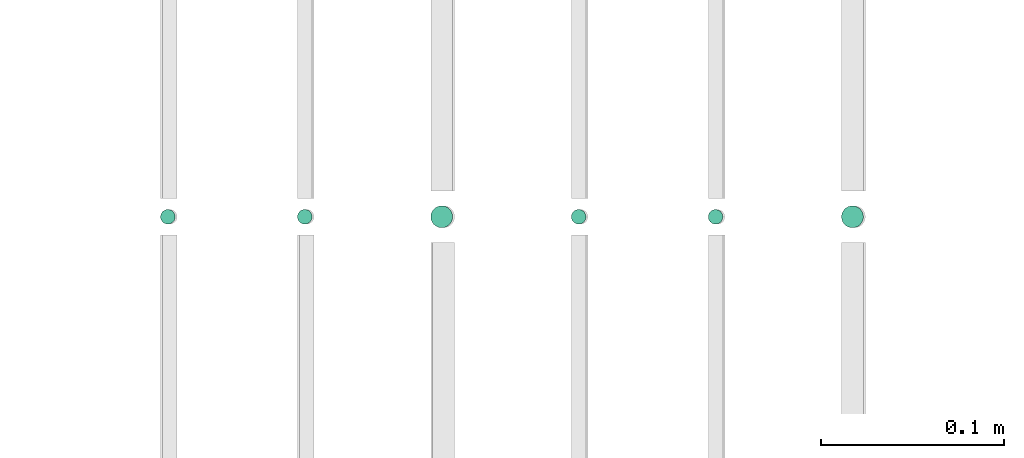
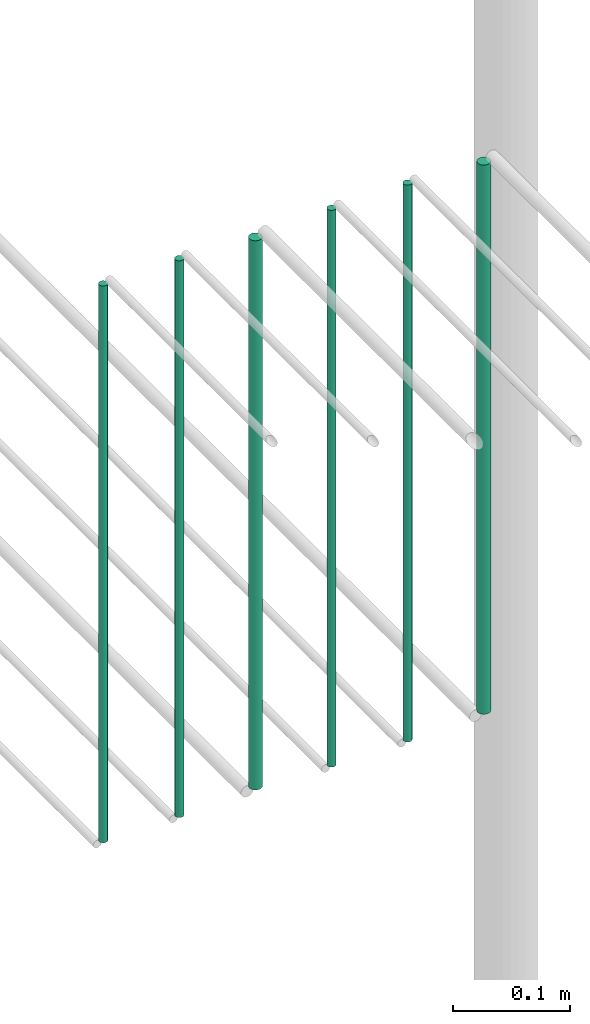
# One storey, part 213 of 331: 6 flow segments.
"""IFC2X3 building model written with IfcOpenShell, lengths in millimetres."""

from ifc_helpers import new_model, entity, si_unit, converted_unit, derived_unit, direction, frame, frame_2d, origin, origin_2d_with_axis, place, context, subcontext, project, spatial, circle, extrude, type_object, element, save


model = new_model("IFC2X3")

# Units and contexts
model_context = context("Model", 3, precision=0.01, world=origin(), true_north=direction((6.12303176911189e-17, 1.0)))
body_context = subcontext(model_context, "Body", "Model", "MODEL_VIEW")
ifc_project = project(units=[si_unit("LENGTHUNIT", "METRE", prefix="MILLI"), si_unit("AREAUNIT", "SQUARE_METRE"), si_unit("VOLUMEUNIT", "CUBIC_METRE"), converted_unit("PLANEANGLEUNIT", "DEGREE", entity("IfcRatioMeasure", 0.0174532925199433), si_unit("PLANEANGLEUNIT", "RADIAN"), dimensions=[0, 0, 0, 0, 0, 0, 0]), si_unit("MASSUNIT", "GRAM", prefix="KILO"), derived_unit("MASSDENSITYUNIT", [(si_unit("MASSUNIT", "GRAM", prefix="KILO"), 1), (si_unit("LENGTHUNIT", "METRE"), -3)]), derived_unit("MOMENTOFINERTIAUNIT", [(si_unit("LENGTHUNIT", "METRE"), 4)]), si_unit("TIMEUNIT", "SECOND"), si_unit("FREQUENCYUNIT", "HERTZ"), si_unit("THERMODYNAMICTEMPERATUREUNIT", "DEGREE_CELSIUS"), derived_unit("THERMALTRANSMITTANCEUNIT", [(si_unit("MASSUNIT", "GRAM", prefix="KILO"), 1), (si_unit("THERMODYNAMICTEMPERATUREUNIT", "KELVIN"), -1), (si_unit("TIMEUNIT", "SECOND"), -3)]), derived_unit("VOLUMETRICFLOWRATEUNIT", [(si_unit("LENGTHUNIT", "METRE"), 3), (si_unit("TIMEUNIT", "SECOND"), -1)]), derived_unit("MASSFLOWRATEUNIT", [(si_unit("MASSUNIT", "GRAM", prefix="KILO"), 1), (si_unit("TIMEUNIT", "SECOND"), -1)]), derived_unit("ROTATIONALFREQUENCYUNIT", [(si_unit("TIMEUNIT", "SECOND"), -1)]), si_unit("ELECTRICCURRENTUNIT", "AMPERE"), si_unit("ELECTRICVOLTAGEUNIT", "VOLT"), si_unit("POWERUNIT", "WATT"), si_unit("FORCEUNIT", "NEWTON", prefix="KILO"), si_unit("ILLUMINANCEUNIT", "LUX"), si_unit("LUMINOUSFLUXUNIT", "LUMEN"), si_unit("LUMINOUSINTENSITYUNIT", "CANDELA"), derived_unit("USERDEFINED", [(si_unit("MASSUNIT", "GRAM", prefix="KILO"), -1), (si_unit("LENGTHUNIT", "METRE"), -2), (si_unit("TIMEUNIT", "SECOND"), 3), (si_unit("LUMINOUSFLUXUNIT", "LUMEN"), 1)]), derived_unit("LINEARVELOCITYUNIT", [(si_unit("LENGTHUNIT", "METRE"), 1), (si_unit("TIMEUNIT", "SECOND"), -1)]), si_unit("PRESSUREUNIT", "PASCAL"), derived_unit("USERDEFINED", [(si_unit("LENGTHUNIT", "METRE"), -2), (si_unit("MASSUNIT", "GRAM", prefix="KILO"), 1), (si_unit("TIMEUNIT", "SECOND"), -2)]), derived_unit("LINEARFORCEUNIT", [(si_unit("MASSUNIT", "GRAM", prefix="KILO"), 1), (si_unit("LENGTHUNIT", "METRE"), 1), (si_unit("TIMEUNIT", "SECOND"), -2), (si_unit("LENGTHUNIT", "METRE"), -1)]), derived_unit("PLANARFORCEUNIT", [(si_unit("MASSUNIT", "GRAM", prefix="KILO"), 1), (si_unit("LENGTHUNIT", "METRE"), 1), (si_unit("TIMEUNIT", "SECOND"), -2), (si_unit("LENGTHUNIT", "METRE"), -2)])], contexts=[model_context])

# Site, building, storey
site_placement = place(None, frame((0.0, -0.00077364408347762, 0.0)))
site = spatial("IfcSite", under=ifc_project, at=site_placement, CompositionType="ELEMENT")
building_placement = place(site_placement, origin())
building = spatial("IfcBuilding", under=site, at=building_placement, CompositionType="ELEMENT")
storey_placement = place(building_placement, origin())
storey = spatial("IfcBuildingStorey", under=building, at=storey_placement, CompositionType="ELEMENT", Elevation=0.0)

# Flow segments
pipe_segment_type = type_object("IfcPipeSegmentType", PredefinedType="NOTDEFINED")
flow_segment_1_placement = place(storey_placement, frame((61864.4468045266, 5638.02529159137, 18460.0)))
element("IfcFlowSegment", 1, at=flow_segment_1_placement, inside=storey, type_object=pipe_segment_type, context=body_context, shape_type="SweptSolid", body=[
    extrude(circle(Radius=4.0, at=frame_2d((0.0, -1.08286712929839e-12), x_axis=(1.0, 0.0))), frame((5.59527223591499, 5.59527223591499, 0.0), z_axis=(0.0, 0.0, 1.0), x_axis=(-1.0, 0.0, 0.0)), (0.0, 0.0, 1.0), 580.000000000015),
])
flow_segment_2_placement = place(storey_placement, frame((61939.4468045266, 5638.02529159137, 18460.0)))
element("IfcFlowSegment", 2, at=flow_segment_2_placement, inside=storey, type_object=pipe_segment_type, context=body_context, shape_type="SweptSolid", body=[
    extrude(circle(Radius=4.0, at=frame_2d((0.0, -1.08286712929839e-12), x_axis=(1.0, 0.0))), frame((5.59527223591499, 5.59527223591499, 0.0), z_axis=(0.0, 0.0, 1.0), x_axis=(-1.0, 0.0, 0.0)), (0.0, 0.0, 1.0), 580.000000000007),
])
flow_segment_3_placement = place(storey_placement, frame((62012.4468045266, 5636.02529159137, 18464.0)))
element("IfcFlowSegment", 3, at=flow_segment_3_placement, inside=storey, type_object=pipe_segment_type, context=body_context, shape_type="SweptSolid", body=[
    extrude(circle(Radius=6.0, at=frame_2d((0.0, -1.08286712929839e-12), x_axis=(1.0, 0.0))), frame((7.59527223591454, 7.59527223591454, 0.0), z_axis=(0.0, 0.0, 1.0), x_axis=(-1.0, 0.0, 0.0)), (0.0, 0.0, 1.0), 572.000000000002),
])
flow_segment_4_placement = place(storey_placement, frame((62089.4468045266, 5638.02529159137, 18460.0)))
element("IfcFlowSegment", 4, at=flow_segment_4_placement, inside=storey, type_object=pipe_segment_type, context=body_context, shape_type="SweptSolid", body=[
    extrude(circle(Radius=4.0, at=frame_2d((0.0, -1.08286712929839e-12), x_axis=(1.0, 0.0))), frame((5.59527223591499, 5.59527223591499, 0.0), z_axis=(0.0, 0.0, 1.0), x_axis=(-1.0, 0.0, 0.0)), (0.0, 0.0, 1.0), 580.000000000015),
])
flow_segment_5_placement = place(storey_placement, frame((62164.4468045266, 5638.02529159137, 18460.0)))
element("IfcFlowSegment", 5, at=flow_segment_5_placement, inside=storey, type_object=pipe_segment_type, context=body_context, shape_type="SweptSolid", body=[
    extrude(circle(Radius=4.0, at=origin_2d_with_axis()), frame((5.59527223591499, 5.59527223591607, 0.0), z_axis=(0.0, 0.0, 1.0), x_axis=(-1.0, 0.0, 0.0)), (0.0, 0.0, 1.0), 580.0),
])
flow_segment_6_placement = place(storey_placement, frame((62237.4468045266, 5636.02529159138, 18464.0)))
element("IfcFlowSegment", 6, at=flow_segment_6_placement, inside=storey, type_object=pipe_segment_type, context=body_context, shape_type="SweptSolid", body=[
    extrude(circle(Radius=6.0, at=frame_2d((0.0, -1.08286712929839e-12), x_axis=(1.0, 0.0))), frame((7.59527223591454, 7.59527223591454, 0.0), z_axis=(0.0, 0.0, 1.0), x_axis=(-1.0, 0.0, 0.0)), (0.0, 0.0, 1.0), 572.000000000011),
])

save(model, "model.ifc")
